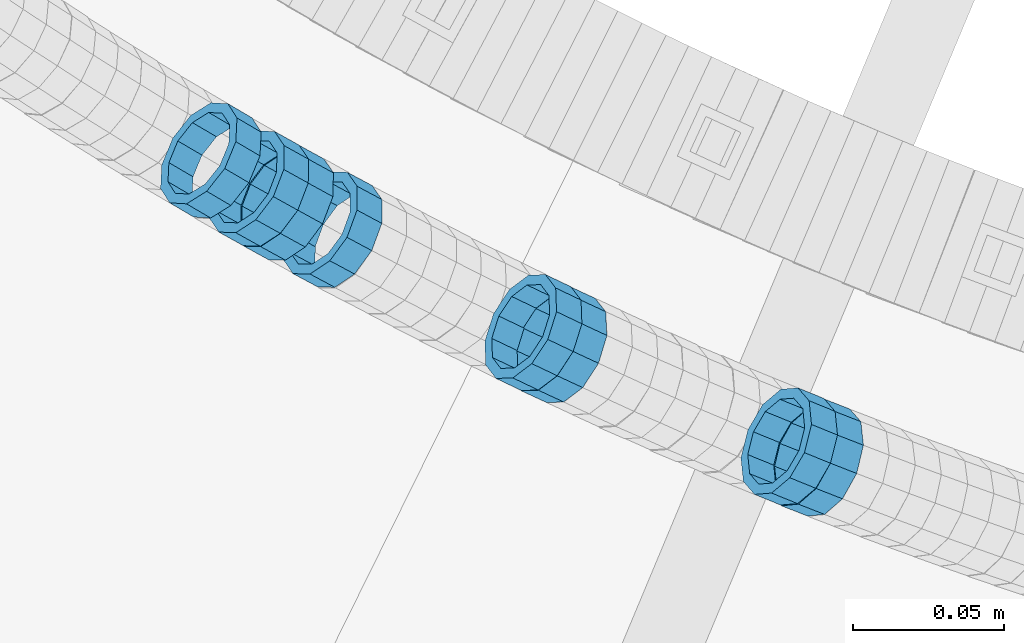
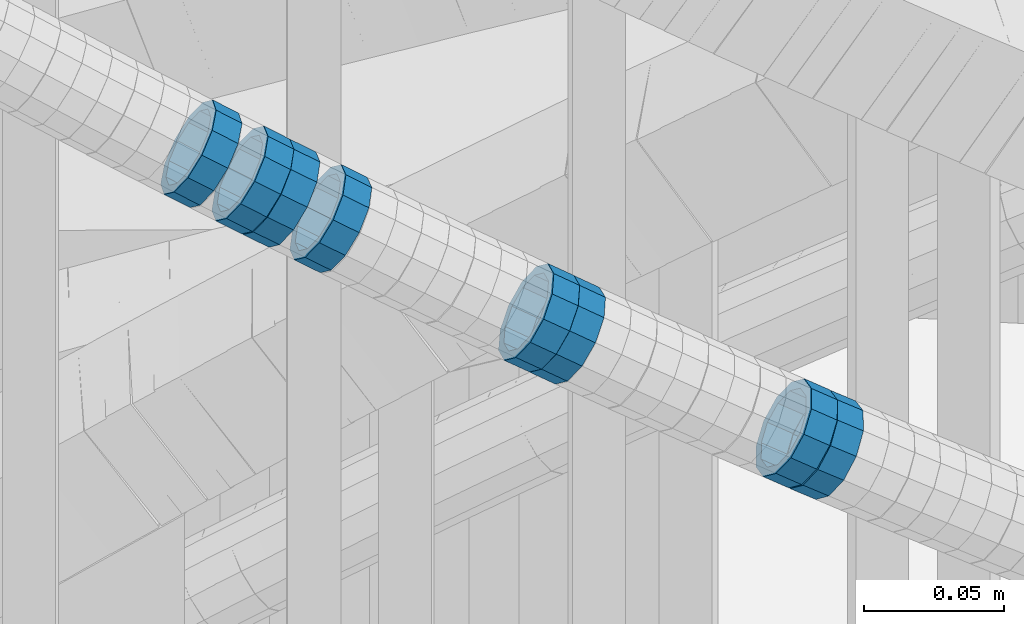
# One storey, part 691 of 975: 8 members.
"""IFC2X3 building model written with IfcOpenShell, lengths in millimetres."""

from ifc_helpers import new_model, si_unit, frame, origin_with_axes, place, context, subcontext, project, spatial, faceted_brep, material, type_object, element, save


model = new_model("IFC2X3")

# Units and contexts
model_context = context("Model", 3, precision=1e-05, world=origin_with_axes())
body_context = subcontext(model_context, "Body", "Model", "MODEL_VIEW")
ifc_project = project(units=[si_unit("LENGTHUNIT", "METRE", prefix="MILLI"), si_unit("AREAUNIT", "SQUARE_METRE"), si_unit("VOLUMEUNIT", "CUBIC_METRE"), si_unit("MASSUNIT", "GRAM", prefix="KILO"), si_unit("TIMEUNIT", "SECOND"), si_unit("PLANEANGLEUNIT", "RADIAN"), si_unit("SOLIDANGLEUNIT", "STERADIAN"), si_unit("THERMODYNAMICTEMPERATUREUNIT", "DEGREE_CELSIUS"), si_unit("LUMINOUSINTENSITYUNIT", "LUMEN")], contexts=[model_context])

# Site, building, storey
site_placement = place(None, origin_with_axes())
site = spatial("IfcSite", under=ifc_project, at=site_placement, CompositionType="ELEMENT")
building_placement = place(site_placement, origin_with_axes())
building = spatial("IfcBuilding", under=site, at=building_placement, Name="Undefined", CompositionType="ELEMENT")
storey_placement = place(building_placement, origin_with_axes())
storey = spatial("IfcBuildingStorey", under=building, at=storey_placement, Name="Undefined", CompositionType="ELEMENT", Elevation=0.0)

# Members
ifc_material = material()
member_type = type_object("IfcMemberType", PredefinedType="NOTDEFINED")
member_1_placement = place(storey_placement, frame((34188.8541716626, 2028.21938033303, 4551.63859488437), z_axis=(-0.363995654703744, -0.93140064599333, -1.66900463227648e-10), x_axis=(-0.795059489986812, 0.310712903994815, 0.520901044991292)))
element("IfcMember", 1, at=member_1_placement, inside=storey, type_object=member_type, material=ifc_material, Name="WALL", context=body_context, shape_type="Brep", body=[
    faceted_brep([(-2.1246523829177e-07, -15.367000000002, 0.0), (-1.83998054126278e-07, -13.3082123799541, 7.68350000000009), (10.9448618081915, -13.3082123799541, 7.68349999999987), (10.944861808206, -15.3669999999875, -1.81898940354586e-12), (-1.06232619145885e-07, -7.68349999999919, 13.3082123799559), (10.9448618081733, -7.68350000000282, 13.3082123799568), (-3.63797880709171e-12, 3.63797880709171e-12, 15.3670000000002), (10.944861808166, -1.09139364212751e-11, 15.3670000000025), (1.06225343188271e-07, 7.68350000000646, 13.3082123799559), (10.9448618081624, 7.68349999998827, 13.3082123799586), (1.8399441614747e-07, 13.308212379965, 7.68350000000009), (10.9448618081697, 13.3082123799468, 7.68350000000214), (2.12461600312963e-07, 15.3670000000093, 0.0), (10.9448618081842, 15.3669999999984, 2.27373675443232e-13), (1.8399441614747e-07, 13.308212379965, -7.68350000000009), (10.9448618082024, 13.3082123799613, -7.68350000000123), (1.06225343188271e-07, 7.68350000000646, -13.3082123799559), (10.944861808217, 7.68350000001374, -13.3082123799586), (-3.63797880709171e-12, 3.63797880709171e-12, -15.3670000000002), (10.9448618082242, 1.45519152283669e-11, -15.3670000000036), (-1.06232619145885e-07, -7.68349999999919, -13.3082123799559), (10.9448618082279, -7.68349999997736, -13.30821237996), (-1.83998054126278e-07, -13.3082123799541, -7.68350000000009), (10.9448618082242, -13.3082123799322, -7.68350000000351), (-2.63386027654633e-07, -19.0500000000029, 0.0), (-2.28097633225843e-07, -16.4977839420972, -9.52499999999964), (10.9448618082242, -16.4977839420681, -9.52500000000418), (10.9448618082097, -19.0499999999847, -2.50111042987555e-12), (-1.31691194837913e-07, -9.52500000000146, -16.4977839420935), (10.9448618082351, -9.52499999997599, -16.4977839420985), (-3.63797880709171e-12, 3.63797880709171e-12, -19.0500000000002), (10.9448618082315, 2.5465851649642e-11, -19.050000000004), (1.31687556859106e-07, 9.52500000000509, -16.4977839420935), (10.9448618082242, 9.52500000001601, -16.4977839420967), (2.28097633225843e-07, 16.4977839421044, -9.52499999999964), (10.9448618082097, 16.4977839421008, -9.52500000000146), (2.63382389675826e-07, 19.0500000000138, 0.0), (10.9448618081842, 19.049999999992, 1.13686837721616e-12), (2.28097633225843e-07, 16.4977839421044, 9.52499999999964), (10.944861808166, 16.4977839420826, 9.52500000000259), (1.31687556859106e-07, 9.52500000000509, 16.4977839420935), (10.9448618081624, 9.52499999998327, 16.4977839420972), (-3.63797880709171e-12, 3.63797880709171e-12, 19.0500000000002), (10.9448618081587, -1.09139364212751e-11, 19.0500000000031), (-1.31691194837913e-07, -9.52500000000146, 16.4977839420935), (10.9448618081697, -9.52500000000873, 16.4977839420953), (-2.28097633225843e-07, -16.4977839420972, 9.52499999999964), (10.9448618081915, -16.4977839420899, 9.52499999999941)], [[[0, 1, 2, 3]], [[1, 4, 5, 2]], [[4, 6, 7, 5]], [[6, 8, 9, 7]], [[8, 10, 11, 9]], [[10, 12, 13, 11]], [[12, 14, 15, 13]], [[14, 16, 17, 15]], [[16, 18, 19, 17]], [[18, 20, 21, 19]], [[20, 22, 23, 21]], [[22, 0, 3, 23]], [[24, 25, 26, 27]], [[25, 28, 29, 26]], [[28, 30, 31, 29]], [[30, 32, 33, 31]], [[32, 34, 35, 33]], [[34, 36, 37, 35]], [[36, 38, 39, 37]], [[38, 40, 41, 39]], [[40, 42, 43, 41]], [[42, 44, 45, 43]], [[44, 46, 47, 45]], [[46, 24, 27, 47]], [[29, 31, 33, 35, 37, 39, 41, 43, 45, 47, 27, 26], [5, 7, 9, 11, 13, 15, 17, 19, 21, 23, 3, 2]], [[46, 44, 42, 40, 38, 36, 34, 32, 30, 28, 25, 24], [22, 20, 18, 16, 14, 12, 10, 8, 6, 4, 1, 0]]]),
])
member_2_placement = place(storey_placement, frame((34180.0485088422, 2031.81185277291, 4557.44322110023), z_axis=(-0.376954751079618, -0.926231674927231, 6.32007868262007e-11), x_axis=(-0.785560127925042, 0.319704702969483, 0.529796364949389)))
element("IfcMember", 2, at=member_2_placement, inside=storey, type_object=member_type, material=ifc_material, Name="WALL", context=body_context, shape_type="Brep", body=[
    faceted_brep([(-2.1246523829177e-07, -15.367000000002, 0.0), (-1.83998054126278e-07, -13.3082123799541, 7.68350000000009), (10.9530817580962, -13.3082123799686, 7.68350000001737), (10.9530817580853, -15.3670000000202, 2.5465851649642e-11), (-1.06232619145885e-07, -7.68349999999919, 13.3082123799559), (10.9530817581108, -7.6835000000101, 13.308212379965), (-3.63797880709171e-12, 3.63797880709171e-12, 15.3670000000002), (10.9530817581144, -3.63797880709171e-12, 15.367000000002), (1.06225343188271e-07, 7.68350000000646, 13.3082123799559), (10.9530817581326, 7.68350000000646, 13.3082123799504), (1.8399441614747e-07, 13.308212379965, 7.68350000000009), (10.9530817581362, 13.308212379965, 7.68349999999191), (2.12461600312963e-07, 15.3670000000093, 0.0), (10.9530817581399, 15.3670000000056, -1.09139364212751e-11), (1.8399441614747e-07, 13.308212379965, -7.68350000000009), (10.9530817581362, 13.3082123799613, -7.68350000000282), (1.06225343188271e-07, 7.68350000000646, -13.3082123799559), (10.9530817581217, 7.68349999999919, -13.3082123799504), (-3.63797880709171e-12, 3.63797880709171e-12, -15.3670000000002), (10.9530817581108, -7.27595761418343e-12, -15.3669999999875), (-1.06232619145885e-07, -7.68349999999919, -13.3082123799559), (10.9530817580999, -7.68350000001374, -13.3082123799359), (-1.83998054126278e-07, -13.3082123799541, -7.68350000000009), (10.9530817580926, -13.3082123799722, -7.68349999997372), (-2.63386027654633e-07, -19.0500000000029, 0.0), (-2.28097633225843e-07, -16.4977839420972, -9.52499999999964), (10.9530817580853, -16.4977839421117, -9.52499999996871), (10.953081758078, -19.0500000000211, 2.91038304567337e-11), (-1.31691194837913e-07, -9.52500000000146, -16.4977839420935), (10.9530817580926, -9.52500000001601, -16.4977839420681), (-3.63797880709171e-12, 3.63797880709171e-12, -19.0500000000002), (10.9530817581071, -7.27595761418343e-12, -19.0499999999884), (1.31687556859106e-07, 9.52500000000509, -16.4977839420935), (10.953081758129, 9.52500000000146, -16.4977839420935), (2.28097633225843e-07, 16.4977839421044, -9.52499999999964), (10.9530817581399, 16.4977839421008, -9.52500000000509), (2.63382389675826e-07, 19.0500000000138, 0.0), (10.9530817581435, 19.0500000000102, -1.09139364212751e-11), (2.28097633225843e-07, 16.4977839421044, 9.52499999999964), (10.9530817581472, 16.4977839421044, 9.5249999999869), (1.31687556859106e-07, 9.52500000000509, 16.4977839420935), (10.9530817581362, 9.52500000000509, 16.4977839420826), (-3.63797880709171e-12, 3.63797880709171e-12, 19.0500000000002), (10.9530817581217, -3.63797880709171e-12, 19.0499999999993), (-1.31691194837913e-07, -9.52500000000146, 16.4977839420935), (10.9530817581035, -9.52500000001237, 16.4977839421081), (-2.28097633225843e-07, -16.4977839420972, 9.52499999999964), (10.953081758089, -16.4977839421081, 9.52500000002328)], [[[0, 1, 2, 3]], [[1, 4, 5, 2]], [[4, 6, 7, 5]], [[6, 8, 9, 7]], [[8, 10, 11, 9]], [[10, 12, 13, 11]], [[12, 14, 15, 13]], [[14, 16, 17, 15]], [[16, 18, 19, 17]], [[18, 20, 21, 19]], [[20, 22, 23, 21]], [[22, 0, 3, 23]], [[24, 25, 26, 27]], [[25, 28, 29, 26]], [[28, 30, 31, 29]], [[30, 32, 33, 31]], [[32, 34, 35, 33]], [[34, 36, 37, 35]], [[36, 38, 39, 37]], [[38, 40, 41, 39]], [[40, 42, 43, 41]], [[42, 44, 45, 43]], [[44, 46, 47, 45]], [[46, 24, 27, 47]], [[29, 31, 33, 35, 37, 39, 41, 43, 45, 47, 27, 26], [5, 7, 9, 11, 13, 15, 17, 19, 21, 23, 3, 2]], [[46, 44, 42, 40, 38, 36, 34, 32, 30, 28, 25, 24], [22, 20, 18, 16, 14, 12, 10, 8, 6, 4, 1, 0]]]),
])
member_3_placement = place(storey_placement, frame((34103.4256664083, 2065.36533131715, 4609.05484070378), z_axis=(-0.421111305950152, -0.907008967982653, -2.33285391004756e-11), x_axis=(-0.76870363894288, 0.356898117973482, 0.530771559960556)))
element("IfcMember", 3, at=member_3_placement, inside=storey, type_object=member_type, material=ifc_material, Name="WALL", context=body_context, shape_type="Brep", body=[
    faceted_brep([(-2.1246523829177e-07, -15.367000000002, 0.0), (-1.83998054126278e-07, -13.3082123799541, 7.68350000000009), (10.9334349588862, -13.3082123799722, 7.68350000000555), (10.9334349588862, -15.3670000000166, 5.45696821063757e-12), (-1.06232619145885e-07, -7.68349999999919, 13.3082123799559), (10.9334349588826, -7.68350000001737, 13.3082123799609), (-3.63797880709171e-12, 3.63797880709171e-12, 15.3670000000002), (10.9334349588862, -1.45519152283669e-11, 15.3670000000043), (1.06225343188271e-07, 7.68350000000646, 13.3082123799559), (10.9334349588898, 7.68349999998827, 13.3082123799591), (1.8399441614747e-07, 13.308212379965, 7.68350000000009), (10.9334349588898, 13.3082123799395, 7.68350000000419), (2.12461600312963e-07, 15.3670000000093, 0.0), (10.9334349588971, 15.3669999999911, 3.63797880709171e-12), (1.8399441614747e-07, 13.308212379965, -7.68350000000009), (10.9334349588935, 13.3082123799431, -7.683499999996), (1.06225343188271e-07, 7.68350000000646, -13.3082123799559), (10.9334349588971, 7.68349999998827, -13.3082123799518), (-3.63797880709171e-12, 3.63797880709171e-12, -15.3670000000002), (10.9334349588971, -1.45519152283669e-11, -15.3669999999961), (-1.06232619145885e-07, -7.68349999999919, -13.3082123799559), (10.9334349588935, -7.68350000001737, -13.3082123799509), (-1.83998054126278e-07, -13.3082123799541, -7.68350000000009), (10.9334349588898, -13.3082123799686, -7.68349999999464), (-2.63386027654633e-07, -19.0500000000029, 0.0), (-2.28097633225843e-07, -16.4977839420972, -9.52499999999964), (10.9334349588898, -16.4977839421117, -9.52499999999372), (10.9334349588898, -19.0500000000211, 5.45696821063757e-12), (-1.31691194837913e-07, -9.52500000000146, -16.4977839420935), (10.9334349588971, -9.52500000001237, -16.4977839420885), (-3.63797880709171e-12, 3.63797880709171e-12, -19.0500000000002), (10.9334349588971, -1.09139364212751e-11, -19.0499999999961), (1.31687556859106e-07, 9.52500000000509, -16.4977839420935), (10.9334349589008, 9.52499999999054, -16.4977839420894), (2.28097633225843e-07, 16.4977839421044, -9.52499999999964), (10.9334349589008, 16.4977839420826, -9.52499999999645), (2.63382389675826e-07, 19.0500000000138, 0.0), (10.9334349588898, 19.0499999999884, 3.18323145620525e-12), (2.28097633225843e-07, 16.4977839421044, 9.52499999999964), (10.9334349588935, 16.497783942079, 9.52500000000282), (1.31687556859106e-07, 9.52500000000509, 16.4977839420935), (10.9334349588826, 9.52499999998327, 16.4977839420976), (-3.63797880709171e-12, 3.63797880709171e-12, 19.0500000000002), (10.9334349588826, -1.81898940354586e-11, 19.0500000000043), (-1.31691194837913e-07, -9.52500000000146, 16.4977839420935), (10.9334349588826, -9.52500000001965, 16.4977839420994), (-2.28097633225843e-07, -16.4977839420972, 9.52499999999964), (10.9334349588826, -16.4977839421117, 9.52500000000646)], [[[0, 1, 2, 3]], [[1, 4, 5, 2]], [[4, 6, 7, 5]], [[6, 8, 9, 7]], [[8, 10, 11, 9]], [[10, 12, 13, 11]], [[12, 14, 15, 13]], [[14, 16, 17, 15]], [[16, 18, 19, 17]], [[18, 20, 21, 19]], [[20, 22, 23, 21]], [[22, 0, 3, 23]], [[24, 25, 26, 27]], [[25, 28, 29, 26]], [[28, 30, 31, 29]], [[30, 32, 33, 31]], [[32, 34, 35, 33]], [[34, 36, 37, 35]], [[36, 38, 39, 37]], [[38, 40, 41, 39]], [[40, 42, 43, 41]], [[42, 44, 45, 43]], [[44, 46, 47, 45]], [[46, 24, 27, 47]], [[29, 31, 33, 35, 37, 39, 41, 43, 45, 47, 27, 26], [5, 7, 9, 11, 13, 15, 17, 19, 21, 23, 3, 2]], [[46, 44, 42, 40, 38, 36, 34, 32, 30, 28, 25, 24], [22, 20, 18, 16, 14, 12, 10, 8, 6, 4, 1, 0]]]),
])
member_4_placement = place(storey_placement, frame((34095.2114542219, 2069.28603887566, 4614.75615254166), z_axis=(-0.429933580617362, -0.902860518716781, 4.16089278587605e-10), x_axis=(-0.769865018035291, 0.366602390016744, 0.522408405023821)))
element("IfcMember", 4, at=member_4_placement, inside=storey, type_object=member_type, material=ifc_material, Name="WALL", context=body_context, shape_type="Brep", body=[
    faceted_brep([(-2.1246523829177e-07, -15.367000000002, 0.0), (-1.83998054126278e-07, -13.3082123799541, 7.68350000000009), (10.9055031979988, -13.3082123799322, 7.68349999999873), (10.9055031979988, -15.3669999999729, -1.81898940354586e-12), (-1.06232619145885e-07, -7.68349999999919, 13.3082123799559), (10.9055031979842, -7.683499999981, 13.3082123799552), (-3.63797880709171e-12, 3.63797880709171e-12, 15.3670000000002), (10.9055031979697, 7.27595761418343e-12, 15.3670000000002), (1.06225343188271e-07, 7.68350000000646, 13.3082123799559), (10.9055031979478, 7.68349999999191, 13.3082123799561), (1.8399441614747e-07, 13.308212379965, 7.68350000000009), (10.9055031979333, 13.3082123799395, 7.68350000000078), (2.12461600312963e-07, 15.3670000000093, 0.0), (10.9055031979187, 15.3669999999802, 4.54747350886464e-13), (1.8399441614747e-07, 13.308212379965, -7.68350000000009), (10.9055031979187, 13.3082123799395, -7.68350000000009), (1.06225343188271e-07, 7.68350000000646, -13.3082123799559), (10.9055031979296, 7.68349999999191, -13.3082123799561), (-3.63797880709171e-12, 3.63797880709171e-12, -15.3670000000002), (10.9055031979478, 3.63797880709171e-12, -15.3670000000013), (-1.06232619145885e-07, -7.68349999999919, -13.3082123799559), (10.9055031979697, -7.683499999981, -13.3082123799575), (-1.83998054126278e-07, -13.3082123799541, -7.68350000000009), (10.9055031979842, -13.3082123799286, -7.68350000000214), (-2.63386027654633e-07, -19.0500000000029, 0.0), (-2.28097633225843e-07, -16.4977839420972, -9.52499999999964), (10.9055031979879, -16.4977839420681, -9.52500000000214), (10.9055031980097, -19.0499999999629, -2.04636307898909e-12), (-1.31691194837913e-07, -9.52500000000146, -16.4977839420935), (10.9055031979624, -9.52499999998327, -16.4977839420956), (-3.63797880709171e-12, 3.63797880709171e-12, -19.0500000000002), (10.9055031979406, 3.63797880709171e-12, -19.0500000000015), (1.31687556859106e-07, 9.52500000000509, -16.4977839420935), (10.9055031979151, 9.5249999999869, -16.4977839420942), (2.28097633225843e-07, 16.4977839421044, -9.52499999999964), (10.9055031979115, 16.4977839420717, -9.52499999999986), (2.63382389675826e-07, 19.0500000000138, 0.0), (10.9055031979115, 19.0499999999774, 6.82121026329696e-13), (2.28097633225843e-07, 16.4977839421044, 9.52499999999964), (10.9055031979296, 16.4977839420753, 9.52500000000123), (1.31687556859106e-07, 9.52500000000509, 16.4977839420935), (10.9055031979515, 9.52499999999054, 16.4977839420942), (-3.63797880709171e-12, 3.63797880709171e-12, 19.0500000000002), (10.9055031979733, 7.27595761418343e-12, 19.0500000000004), (-1.31691194837913e-07, -9.52500000000146, 16.4977839420935), (10.9055031979988, -9.52499999997599, 16.4977839420933), (-2.28097633225843e-07, -16.4977839420972, 9.52499999999964), (10.905503198006, -16.4977839420644, 9.52499999999873)], [[[0, 1, 2, 3]], [[1, 4, 5, 2]], [[4, 6, 7, 5]], [[6, 8, 9, 7]], [[8, 10, 11, 9]], [[10, 12, 13, 11]], [[12, 14, 15, 13]], [[14, 16, 17, 15]], [[16, 18, 19, 17]], [[18, 20, 21, 19]], [[20, 22, 23, 21]], [[22, 0, 3, 23]], [[24, 25, 26, 27]], [[25, 28, 29, 26]], [[28, 30, 31, 29]], [[30, 32, 33, 31]], [[32, 34, 35, 33]], [[34, 36, 37, 35]], [[36, 38, 39, 37]], [[38, 40, 41, 39]], [[40, 42, 43, 41]], [[42, 44, 45, 43]], [[44, 46, 47, 45]], [[46, 24, 27, 47]], [[29, 31, 33, 35, 37, 39, 41, 43, 45, 47, 27, 26], [5, 7, 9, 11, 13, 15, 17, 19, 21, 23, 3, 2]], [[46, 44, 42, 40, 38, 36, 34, 32, 30, 28, 25, 24], [22, 20, 18, 16, 14, 12, 10, 8, 6, 4, 1, 0]]]),
])
member_5_placement = place(storey_placement, frame((34028.6178318027, 2103.17161594797, 4660.73299991163), z_axis=(-0.472817704685476, -0.881160268132851, -2.11884071177337e-10), x_axis=(-0.747806728747568, 0.401262146864522, 0.528936466821428)))
element("IfcMember", 5, at=member_5_placement, inside=storey, type_object=member_type, material=ifc_material, Name="WALL", context=body_context, shape_type="Brep", body=[
    faceted_brep([(-2.1246523829177e-07, -15.367000000002, 0.0), (-1.83998054126278e-07, -13.3082123799541, 7.68350000000009), (10.9726933794955, -13.3082123799577, 7.68349999999873), (10.9726933795027, -15.3669999999984, -3.18323145620525e-12), (-1.06232619145885e-07, -7.68349999999919, 13.3082123799559), (10.9726933794846, -7.6835000000101, 13.308212379955), (-3.63797880709171e-12, 3.63797880709171e-12, 15.3670000000002), (10.9726933794773, -1.09139364212751e-11, 15.3670000000011), (1.06225343188271e-07, 7.68350000000646, 13.3082123799559), (10.9726933794773, 7.68349999998827, 13.3082123799563), (1.8399441614747e-07, 13.308212379965, 7.68350000000009), (10.9726933794846, 13.3082123799504, 7.68350000000146), (2.12461600312963e-07, 15.3670000000093, 0.0), (10.9726933794882, 15.3669999999984, 9.09494701772928e-13), (1.8399441614747e-07, 13.308212379965, -7.68350000000009), (10.9726933794955, 13.3082123799613, -7.68350000000055), (1.06225343188271e-07, 7.68350000000646, -13.3082123799559), (10.97269337951, 7.68350000001374, -13.3082123799572), (-3.63797880709171e-12, 3.63797880709171e-12, -15.3670000000002), (10.97269337951, 1.09139364212751e-11, -15.3670000000029), (-1.06232619145885e-07, -7.68349999999919, -13.3082123799559), (10.9726933795137, -7.68349999998463, -13.3082123799586), (-1.83998054126278e-07, -13.3082123799541, -7.68350000000009), (10.9726933795064, -13.3082123799468, -7.68350000000328), (-2.63386027654633e-07, -19.0500000000029, 0.0), (-2.28097633225843e-07, -16.4977839420972, -9.52499999999964), (10.97269337951, -16.4977839420826, -9.52500000000418), (10.9726933795027, -19.0499999999993, -2.27373675443232e-12), (-1.31691194837913e-07, -9.52500000000146, -16.4977839420935), (10.9726933795137, -9.52499999998327, -16.4977839420976), (-3.63797880709171e-12, 3.63797880709171e-12, -19.0500000000002), (10.9726933795209, 1.81898940354586e-11, -19.0500000000034), (1.31687556859106e-07, 9.52500000000509, -16.4977839420935), (10.97269337951, 9.52500000001237, -16.4977839420958), (2.28097633225843e-07, 16.4977839421044, -9.52499999999964), (10.9726933795027, 16.4977839421008, -9.525000000001), (2.63382389675826e-07, 19.0500000000138, 0.0), (10.9726933794882, 19.0499999999993, 4.54747350886464e-13), (2.28097633225843e-07, 16.4977839421044, 9.52499999999964), (10.9726933794809, 16.4977839420826, 9.52500000000236), (1.31687556859106e-07, 9.52500000000509, 16.4977839420935), (10.97269337947, 9.5249999999869, 16.4977839420967), (-3.63797880709171e-12, 3.63797880709171e-12, 19.0500000000002), (10.9726933794736, -1.81898940354586e-11, 19.0500000000015), (-1.31691194837913e-07, -9.52500000000146, 16.4977839420935), (10.9726933794809, -9.52500000001237, 16.4977839420931), (-2.28097633225843e-07, -16.4977839420972, 9.52499999999964), (10.9726933794882, -16.4977839420972, 9.52499999999827)], [[[0, 1, 2, 3]], [[1, 4, 5, 2]], [[4, 6, 7, 5]], [[6, 8, 9, 7]], [[8, 10, 11, 9]], [[10, 12, 13, 11]], [[12, 14, 15, 13]], [[14, 16, 17, 15]], [[16, 18, 19, 17]], [[18, 20, 21, 19]], [[20, 22, 23, 21]], [[22, 0, 3, 23]], [[24, 25, 26, 27]], [[25, 28, 29, 26]], [[28, 30, 31, 29]], [[30, 32, 33, 31]], [[32, 34, 35, 33]], [[34, 36, 37, 35]], [[36, 38, 39, 37]], [[38, 40, 41, 39]], [[40, 42, 43, 41]], [[42, 44, 45, 43]], [[44, 46, 47, 45]], [[46, 24, 27, 47]], [[29, 31, 33, 35, 37, 39, 41, 43, 45, 47, 27, 26], [5, 7, 9, 11, 13, 15, 17, 19, 21, 23, 3, 2]], [[46, 44, 42, 40, 38, 36, 34, 32, 30, 28, 25, 24], [22, 20, 18, 16, 14, 12, 10, 8, 6, 4, 1, 0]]]),
])
member_6_placement = place(storey_placement, frame((34012.5060080701, 2112.07662631419, 4672.13253960965), z_axis=(-0.481097727683301, -0.876666970073565, -1.90757418749854e-10), x_axis=(-0.748616549316821, 0.410826155173783, 0.520379796220129)))
element("IfcMember", 6, at=member_6_placement, inside=storey, type_object=member_type, material=ifc_material, Name="WALL", context=body_context, shape_type="Brep", body=[
    faceted_brep([(-2.1246523829177e-07, -15.367000000002, 0.0), (-1.83998054126278e-07, -13.3082123799541, 7.68350000000009), (10.9530817580962, -13.3082123799686, 7.68350000001737), (10.9530817580853, -15.3670000000202, 2.5465851649642e-11), (-1.06232619145885e-07, -7.68349999999919, 13.3082123799559), (10.9530817581108, -7.6835000000101, 13.308212379965), (-3.63797880709171e-12, 3.63797880709171e-12, 15.3670000000002), (10.9530817581144, -3.63797880709171e-12, 15.367000000002), (1.06225343188271e-07, 7.68350000000646, 13.3082123799559), (10.9530817581326, 7.68350000000646, 13.3082123799504), (1.8399441614747e-07, 13.308212379965, 7.68350000000009), (10.9530817581362, 13.308212379965, 7.68349999999191), (2.12461600312963e-07, 15.3670000000093, 0.0), (10.9530817581399, 15.3670000000056, -1.09139364212751e-11), (1.8399441614747e-07, 13.308212379965, -7.68350000000009), (10.9530817581362, 13.3082123799613, -7.68350000000282), (1.06225343188271e-07, 7.68350000000646, -13.3082123799559), (10.9530817581217, 7.68349999999919, -13.3082123799504), (-3.63797880709171e-12, 3.63797880709171e-12, -15.3670000000002), (10.9530817581108, -7.27595761418343e-12, -15.3669999999875), (-1.06232619145885e-07, -7.68349999999919, -13.3082123799559), (10.9530817580999, -7.68350000001374, -13.3082123799359), (-1.83998054126278e-07, -13.3082123799541, -7.68350000000009), (10.9530817580926, -13.3082123799722, -7.68349999997372), (-2.63386027654633e-07, -19.0500000000029, 0.0), (-2.28097633225843e-07, -16.4977839420972, -9.52499999999964), (10.9530817580853, -16.4977839421117, -9.52499999996871), (10.953081758078, -19.0500000000211, 2.91038304567337e-11), (-1.31691194837913e-07, -9.52500000000146, -16.4977839420935), (10.9530817580926, -9.52500000001601, -16.4977839420681), (-3.63797880709171e-12, 3.63797880709171e-12, -19.0500000000002), (10.9530817581071, -7.27595761418343e-12, -19.0499999999884), (1.31687556859106e-07, 9.52500000000509, -16.4977839420935), (10.953081758129, 9.52500000000146, -16.4977839420935), (2.28097633225843e-07, 16.4977839421044, -9.52499999999964), (10.9530817581399, 16.4977839421008, -9.52500000000509), (2.63382389675826e-07, 19.0500000000138, 0.0), (10.9530817581435, 19.0500000000102, -1.09139364212751e-11), (2.28097633225843e-07, 16.4977839421044, 9.52499999999964), (10.9530817581472, 16.4977839421044, 9.5249999999869), (1.31687556859106e-07, 9.52500000000509, 16.4977839420935), (10.9530817581362, 9.52500000000509, 16.4977839420826), (-3.63797880709171e-12, 3.63797880709171e-12, 19.0500000000002), (10.9530817581217, -3.63797880709171e-12, 19.0499999999993), (-1.31691194837913e-07, -9.52500000000146, 16.4977839420935), (10.9530817581035, -9.52500000001237, 16.4977839421081), (-2.28097633225843e-07, -16.4977839420972, 9.52499999999964), (10.953081758089, -16.4977839421081, 9.52500000002328)], [[[0, 1, 2, 3]], [[1, 4, 5, 2]], [[4, 6, 7, 5]], [[6, 8, 9, 7]], [[8, 10, 11, 9]], [[10, 12, 13, 11]], [[12, 14, 15, 13]], [[14, 16, 17, 15]], [[16, 18, 19, 17]], [[18, 20, 21, 19]], [[20, 22, 23, 21]], [[22, 0, 3, 23]], [[24, 25, 26, 27]], [[25, 28, 29, 26]], [[28, 30, 31, 29]], [[30, 32, 33, 31]], [[32, 34, 35, 33]], [[34, 36, 37, 35]], [[36, 38, 39, 37]], [[38, 40, 41, 39]], [[40, 42, 43, 41]], [[42, 44, 45, 43]], [[44, 46, 47, 45]], [[46, 24, 27, 47]], [[29, 31, 33, 35, 37, 39, 41, 43, 45, 47, 27, 26], [5, 7, 9, 11, 13, 15, 17, 19, 21, 23, 3, 2]], [[46, 44, 42, 40, 38, 36, 34, 32, 30, 28, 25, 24], [22, 20, 18, 16, 14, 12, 10, 8, 6, 4, 1, 0]]]),
])
member_7_placement = place(storey_placement, frame((34004.161165411, 2116.71597390122, 4677.95245632412), z_axis=(-0.485642930938862, -0.874157276254743, -1.10892869997769e-10), x_axis=(-0.740970753287183, 0.411650418159604, 0.530571650205745)))
element("IfcMember", 7, at=member_7_placement, inside=storey, type_object=member_type, material=ifc_material, Name="WALL", context=body_context, shape_type="Brep", body=[
    faceted_brep([(-2.1246523829177e-07, -15.367000000002, 0.0), (-1.83998054126278e-07, -13.3082123799541, 7.68350000000009), (10.9334349588862, -13.3082123799722, 7.68350000000555), (10.9334349588862, -15.3670000000166, 5.45696821063757e-12), (-1.06232619145885e-07, -7.68349999999919, 13.3082123799559), (10.9334349588826, -7.68350000001737, 13.3082123799609), (-3.63797880709171e-12, 3.63797880709171e-12, 15.3670000000002), (10.9334349588862, -1.45519152283669e-11, 15.3670000000043), (1.06225343188271e-07, 7.68350000000646, 13.3082123799559), (10.9334349588898, 7.68349999998827, 13.3082123799591), (1.8399441614747e-07, 13.308212379965, 7.68350000000009), (10.9334349588898, 13.3082123799395, 7.68350000000419), (2.12461600312963e-07, 15.3670000000093, 0.0), (10.9334349588971, 15.3669999999911, 3.63797880709171e-12), (1.8399441614747e-07, 13.308212379965, -7.68350000000009), (10.9334349588935, 13.3082123799431, -7.683499999996), (1.06225343188271e-07, 7.68350000000646, -13.3082123799559), (10.9334349588971, 7.68349999998827, -13.3082123799518), (-3.63797880709171e-12, 3.63797880709171e-12, -15.3670000000002), (10.9334349588971, -1.45519152283669e-11, -15.3669999999961), (-1.06232619145885e-07, -7.68349999999919, -13.3082123799559), (10.9334349588935, -7.68350000001737, -13.3082123799509), (-1.83998054126278e-07, -13.3082123799541, -7.68350000000009), (10.9334349588898, -13.3082123799686, -7.68349999999464), (-2.63386027654633e-07, -19.0500000000029, 0.0), (-2.28097633225843e-07, -16.4977839420972, -9.52499999999964), (10.9334349588898, -16.4977839421117, -9.52499999999372), (10.9334349588898, -19.0500000000211, 5.45696821063757e-12), (-1.31691194837913e-07, -9.52500000000146, -16.4977839420935), (10.9334349588971, -9.52500000001237, -16.4977839420885), (-3.63797880709171e-12, 3.63797880709171e-12, -19.0500000000002), (10.9334349588971, -1.09139364212751e-11, -19.0499999999961), (1.31687556859106e-07, 9.52500000000509, -16.4977839420935), (10.9334349589008, 9.52499999999054, -16.4977839420894), (2.28097633225843e-07, 16.4977839421044, -9.52499999999964), (10.9334349589008, 16.4977839420826, -9.52499999999645), (2.63382389675826e-07, 19.0500000000138, 0.0), (10.9334349588898, 19.0499999999884, 3.18323145620525e-12), (2.28097633225843e-07, 16.4977839421044, 9.52499999999964), (10.9334349588935, 16.497783942079, 9.52500000000282), (1.31687556859106e-07, 9.52500000000509, 16.4977839420935), (10.9334349588826, 9.52499999998327, 16.4977839420976), (-3.63797880709171e-12, 3.63797880709171e-12, 19.0500000000002), (10.9334349588826, -1.81898940354586e-11, 19.0500000000043), (-1.31691194837913e-07, -9.52500000000146, 16.4977839420935), (10.9334349588826, -9.52500000001965, 16.4977839420994), (-2.28097633225843e-07, -16.4977839420972, 9.52499999999964), (10.9334349588826, -16.4977839421117, 9.52500000000646)], [[[0, 1, 2, 3]], [[1, 4, 5, 2]], [[4, 6, 7, 5]], [[6, 8, 9, 7]], [[8, 10, 11, 9]], [[10, 12, 13, 11]], [[12, 14, 15, 13]], [[14, 16, 17, 15]], [[16, 18, 19, 17]], [[18, 20, 21, 19]], [[20, 22, 23, 21]], [[22, 0, 3, 23]], [[24, 25, 26, 27]], [[25, 28, 29, 26]], [[28, 30, 31, 29]], [[30, 32, 33, 31]], [[32, 34, 35, 33]], [[34, 36, 37, 35]], [[36, 38, 39, 37]], [[38, 40, 41, 39]], [[40, 42, 43, 41]], [[42, 44, 45, 43]], [[44, 46, 47, 45]], [[46, 24, 27, 47]], [[29, 31, 33, 35, 37, 39, 41, 43, 45, 47, 27, 26], [5, 7, 9, 11, 13, 15, 17, 19, 21, 23, 3, 2]], [[46, 44, 42, 40, 38, 36, 34, 32, 30, 28, 25, 24], [22, 20, 18, 16, 14, 12, 10, 8, 6, 4, 1, 0]]]),
])
member_8_placement = place(storey_placement, frame((33988.1990037746, 2125.95848735499, 4689.36824012302), z_axis=(-0.506549048880574, -0.862211146459025, 1.05085746326949e-10), x_axis=(-0.734656395984671, 0.431610632990997, 0.523442681989084)))
element("IfcMember", 8, at=member_8_placement, inside=storey, type_object=member_type, material=ifc_material, Name="WALL", context=body_context, shape_type="Brep", body=[
    faceted_brep([(-2.1246523829177e-07, -15.367000000002, 0.0), (-1.83998054126278e-07, -13.3082123799541, 7.68350000000009), (10.8908218239267, -13.3082123799468, 7.68349999999828), (10.8908218239521, -15.3669999999729, -6.3664629124105e-12), (-1.06232619145885e-07, -7.68349999999919, 13.3082123799559), (10.8908218238939, -7.6835000000101, 13.3082123799586), (-3.63797880709171e-12, 3.63797880709171e-12, 15.3670000000002), (10.8908218238757, -2.18278728425503e-11, 15.3670000000075), (1.06225343188271e-07, 7.68350000000646, 13.3082123799559), (10.8908218238612, 7.68349999996644, 13.308212379965), (1.8399441614747e-07, 13.308212379965, 7.68350000000009), (10.8908218238612, 13.308212379925, 7.68350000000919), (2.12461600312963e-07, 15.3670000000093, 0.0), (10.8908218238794, 15.3669999999802, 5.45696821063757e-12), (1.8399441614747e-07, 13.308212379965, -7.68350000000009), (10.8908218239012, 13.3082123799541, -7.68349999999828), (1.06225343188271e-07, 7.68350000000646, -13.3082123799559), (10.8908218239339, 7.68350000001737, -13.30821237996), (-3.63797880709171e-12, 3.63797880709171e-12, -15.3670000000002), (10.8908218239558, 3.27418092638254e-11, -15.3670000000075), (-1.06232619145885e-07, -7.68349999999919, -13.3082123799559), (10.890821823974, -7.68349999996281, -13.308212379965), (-1.83998054126278e-07, -13.3082123799541, -7.68350000000009), (10.8908218239667, -13.3082123799177, -7.68350000000919), (-2.63386027654633e-07, -19.0500000000029, 0.0), (-2.28097633225843e-07, -16.4977839420972, -9.52499999999964), (10.8908218239812, -16.4977839420499, -9.52500000001055), (10.8908218239594, -19.0499999999665, -7.73070496506989e-12), (-1.31691194837913e-07, -9.52500000000146, -16.4977839420935), (10.8908218239812, -9.52499999994689, -16.4977839421063), (-3.63797880709171e-12, 3.63797880709171e-12, -19.0500000000002), (10.8908218239703, 3.63797880709171e-11, -19.0500000000093), (1.31687556859106e-07, 9.52500000000509, -16.4977839420935), (10.8908218239412, 9.52500000002328, -16.4977839420981), (2.28097633225843e-07, 16.4977839421044, -9.52499999999964), (10.8908218239048, 16.4977839420899, -9.52499999999873), (2.63382389675826e-07, 19.0500000000138, 0.0), (10.8908218238685, 19.0499999999774, 6.82121026329696e-12), (2.28097633225843e-07, 16.4977839421044, 9.52499999999964), (10.8908218238539, 16.4977839420535, 9.525000000011), (1.31687556859106e-07, 9.52500000000509, 16.4977839420935), (10.8908218238466, 9.52499999996144, 16.4977839421058), (-3.63797880709171e-12, 3.63797880709171e-12, 19.0500000000002), (10.8908218238648, -3.27418092638254e-11, 19.0500000000097), (-1.31691194837913e-07, -9.52500000000146, 16.4977839420935), (10.8908218238939, -9.52500000000873, 16.4977839420972), (-2.28097633225843e-07, -16.4977839420972, 9.52499999999964), (10.8908218239267, -16.4977839420826, 9.52499999999873)], [[[0, 1, 2, 3]], [[1, 4, 5, 2]], [[4, 6, 7, 5]], [[6, 8, 9, 7]], [[8, 10, 11, 9]], [[10, 12, 13, 11]], [[12, 14, 15, 13]], [[14, 16, 17, 15]], [[16, 18, 19, 17]], [[18, 20, 21, 19]], [[20, 22, 23, 21]], [[22, 0, 3, 23]], [[24, 25, 26, 27]], [[25, 28, 29, 26]], [[28, 30, 31, 29]], [[30, 32, 33, 31]], [[32, 34, 35, 33]], [[34, 36, 37, 35]], [[36, 38, 39, 37]], [[38, 40, 41, 39]], [[40, 42, 43, 41]], [[42, 44, 45, 43]], [[44, 46, 47, 45]], [[46, 24, 27, 47]], [[29, 31, 33, 35, 37, 39, 41, 43, 45, 47, 27, 26], [5, 7, 9, 11, 13, 15, 17, 19, 21, 23, 3, 2]], [[46, 44, 42, 40, 38, 36, 34, 32, 30, 28, 25, 24], [22, 20, 18, 16, 14, 12, 10, 8, 6, 4, 1, 0]]]),
])

save(model, "model.ifc")
